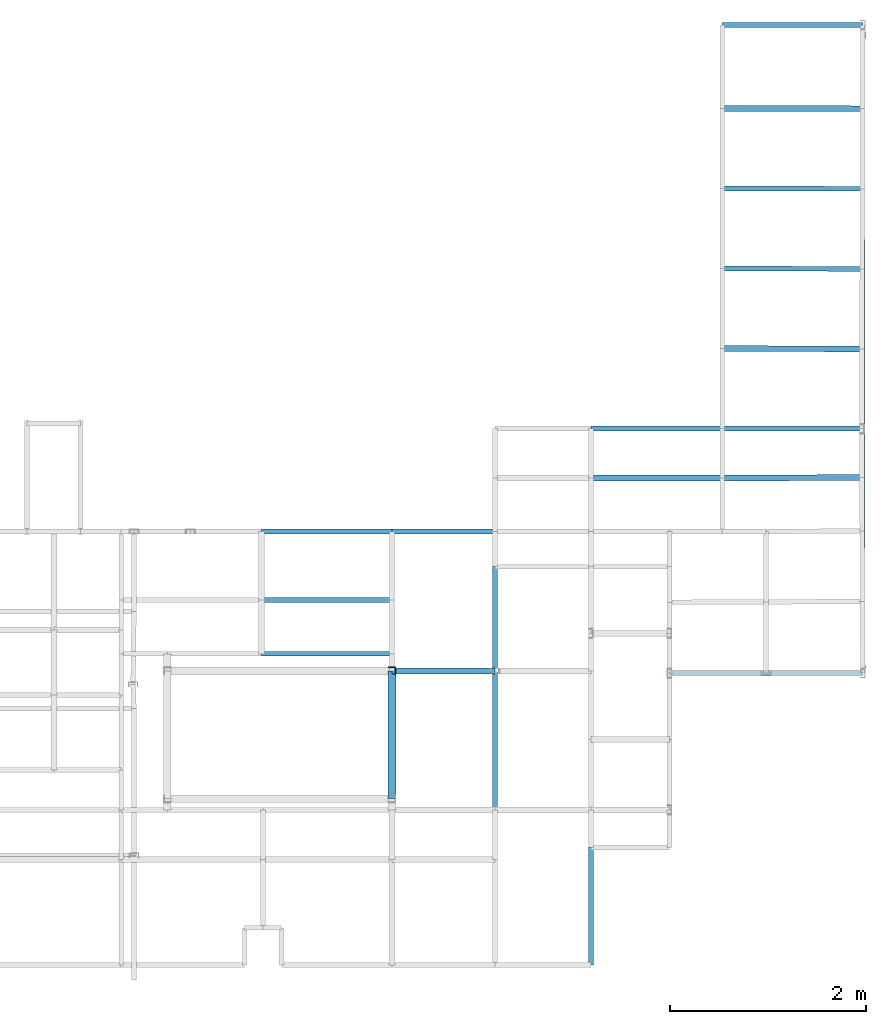
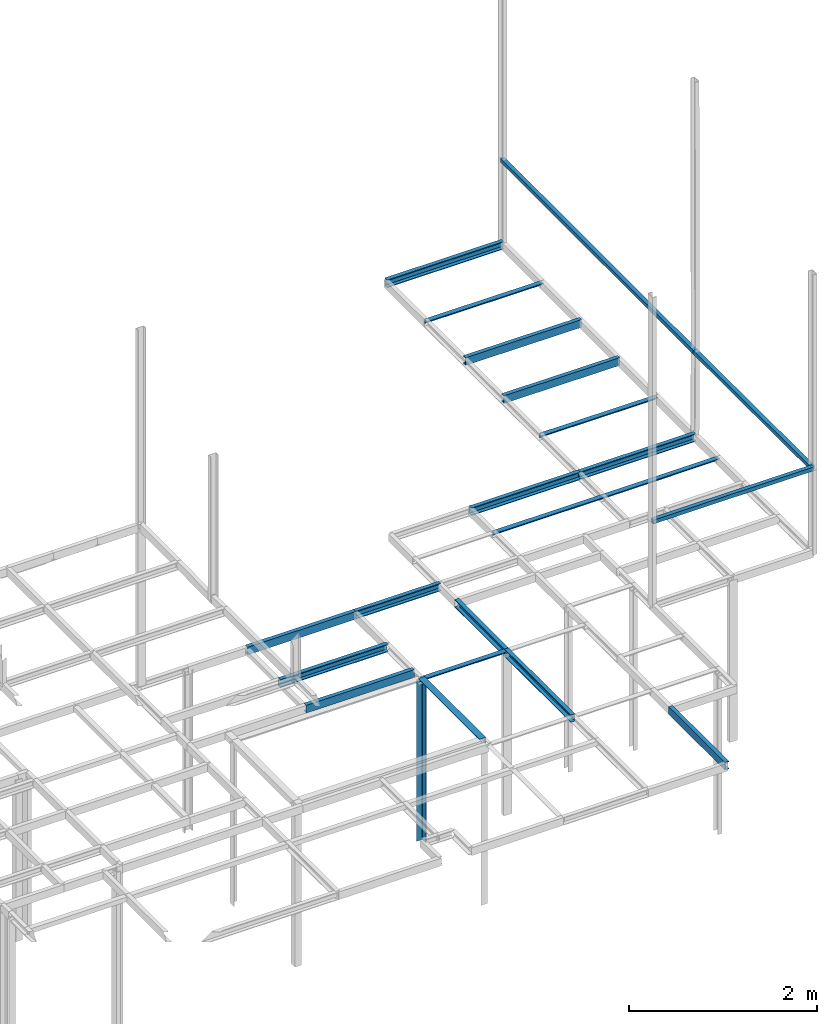
# Not in any storey, part 4 of 7: 21 beams, 1 member, 3 openings.
"""IFC2X3 model written with IfcOpenShell, lengths in centimetres."""

from ifc_helpers import new_model, si_unit, frame, frame_2d, origin_with_axes, origin_2d_with_axis, place, context, project, polyline, rectangle, l_section, u_section, outline, extrude, material, element, save


model = new_model("IFC2X3")

# Units and contexts
model_context = context("Model", 3, precision=1e-05, world=origin_with_axes())
plan_context = context("Plan", 3, precision=1e-05, world=origin_with_axes())
ifc_project = project(units=[si_unit("LENGTHUNIT", "METRE", prefix="CENTI"), si_unit("AREAUNIT", "SQUARE_METRE", prefix="CENTI"), si_unit("VOLUMEUNIT", "CUBIC_METRE", prefix="CENTI"), si_unit("PLANEANGLEUNIT", "RADIAN"), si_unit("SOLIDANGLEUNIT", "STERADIAN"), si_unit("MASSUNIT", "GRAM"), si_unit("TIMEUNIT", "SECOND"), si_unit("THERMODYNAMICTEMPERATUREUNIT", "DEGREE_CELSIUS"), si_unit("LUMINOUSINTENSITYUNIT", "LUMEN")], contexts=[model_context, plan_context])

# Member
ifc_material = material()
member_placement = place(None, frame((8.199999809265, 132.699996948242, 0.0), z_axis=(0.0, 0.0, 1.0), x_axis=(-1.0, 0.0, 0.0)))
element("IfcMember", 1, at=member_placement, material=ifc_material, context=model_context, shape_type="SweptSolid", body=[
    extrude(l_section(Depth=8.0, Width=8.0, Thickness=0.8, FilletRadius=1.0, EdgeRadius=0.0, LegSlope=0.0, CentreOfGravityInX=0.0, CentreOfGravityInY=0.0, at=origin_2d_with_axis()), origin_with_axes(), (0.0, 0.0, 1.0), 210.0),
])

# Beams
beam_1_placement = place(None, frame((488.5, 791.700012207031, 210.0), z_axis=(-1.0, 0.0, 0.0), x_axis=(0.0, -1.0, 0.0)))
element("IfcBeam", 2, at=beam_1_placement, material=ifc_material, Name="UPN - de ala UPN 100", context=model_context, shape_type="SweptSolid", body=[
    extrude(u_section(Depth=10.0, FlangeWidth=5.0, WebThickness=0.6, FlangeThickness=0.85, FilletRadius=0.0, EdgeRadius=0.0, FlangeSlope=0.0, CentreOfGravityInX=0.0, at=origin_2d_with_axis()), origin_with_axes(), (0.0, 0.0, 1.0), 143.399993896484),
])
beam_2_placement = place(None, frame((488.300018310547, 706.200012207031, 210.0), z_axis=(-0.999997805732, 0.002094882047, 0.0), x_axis=(0.0, 0.0, 1.0)))
element("IfcBeam", 3, at=beam_2_placement, material=ifc_material, context=model_context, shape_type="SweptSolid", body=[
    extrude(outline(polyline([(3.0, -3.000006586926), (3.0, 3.000006586926), (-3.0, 3.000006586926), (-3.0, 2.500005510415), (2.5, 2.500005510415), (2.5, -3.000006586926), (3.0, -3.000006586926)])), origin_with_axes(), (0.0, 0.0, 1.0), 143.200326426897),
])
beam_3_placement = place(None, frame((488.100006103516, 624.5, 210.0), z_axis=(-0.999996087374, 0.00279736258, 0.0), x_axis=(0.002797362627, 0.999996066093, 0.0)))
element("IfcBeam", 4, at=beam_3_placement, material=ifc_material, Name="UPN - de ala UPN 100", context=model_context, shape_type="SweptSolid", body=[
    extrude(u_section(Depth=10.0, FlangeWidth=5.0, WebThickness=0.6, FlangeThickness=0.85, FilletRadius=0.0, EdgeRadius=0.0, FlangeSlope=0.0, CentreOfGravityInX=0.0, at=frame_2d((-1.5323e-08, 0.0), x_axis=(1.0, 0.0))), origin_with_axes(), (0.0, 0.0, 1.0), 143.000559507758),
])
beam_4_placement = place(None, frame((487.899993896484, 542.799987792969, 210.0), z_axis=(-0.999996076406, 0.002801280663, 0.0), x_axis=(0.002801280702, 0.999996066093, 0.0)))
element("IfcBeam", 5, at=beam_4_placement, material=ifc_material, Name="UPN - de ala UPN 100", context=model_context, shape_type="SweptSolid", body=[
    extrude(u_section(Depth=10.0, FlangeWidth=5.0, WebThickness=0.6, FlangeThickness=0.85, FilletRadius=0.0, EdgeRadius=0.0, FlangeSlope=0.0, CentreOfGravityInX=0.0, at=frame_2d((-9.58e-09, 0.0), x_axis=(1.0, 0.0))), origin_with_axes(), (0.0, 0.0, 1.0), 142.800548084396),
])
beam_5_placement = place(None, frame((487.700012207031, 461.200012207031, 210.0), z_axis=(-0.999997787228, 0.002103696468, 0.0), x_axis=(0.0, 0.0, 1.0)))
element("IfcBeam", 6, at=beam_5_placement, material=ifc_material, context=model_context, shape_type="SweptSolid", body=[
    extrude(outline(polyline([(3.0, -3.000006651027), (3.0, 3.000006651027), (-3.0, 3.000006651027), (-3.0, 2.500005510422), (2.5, 2.500005510422), (2.5, -3.000006651027), (3.0, -3.000006651027)])), origin_with_axes(), (0.0, 0.0, 1.0), 142.600321645495),
])
beam_6_placement = place(None, frame((345.100006103516, 379.800018310547, 210.0), z_axis=(-1.0, 0.0, 0.0), x_axis=(0.0, -1.0, 0.0)))
element("IfcBeam", 7, at=beam_6_placement, material=ifc_material, Name="UPN - de ala UPN 100", context=model_context, shape_type="SweptSolid", body=[
    extrude(u_section(Depth=10.0, FlangeWidth=5.0, WebThickness=0.6, FlangeThickness=0.85, FilletRadius=0.0, EdgeRadius=0.0, FlangeSlope=0.0, CentreOfGravityInX=0.0, at=origin_2d_with_axis()), origin_with_axes(), (0.0, 0.0, 1.0), 134.0),
])
beam_7_placement = place(None, frame((487.5, 379.800018310547, 210.0), z_axis=(-1.0, 0.0, 0.0), x_axis=(0.0, -1.0, 0.0)))
element("IfcBeam", 8, at=beam_7_placement, material=ifc_material, Name="UPN - de ala UPN 100", context=model_context, shape_type="SweptSolid", body=[
    extrude(u_section(Depth=10.0, FlangeWidth=5.0, WebThickness=0.6, FlangeThickness=0.85, FilletRadius=0.0, EdgeRadius=0.0, FlangeSlope=0.0, CentreOfGravityInX=0.0, at=origin_2d_with_axis()), origin_with_axes(), (0.0, 0.0, 1.0), 142.399993896484),
])
beam_8_placement = place(None, frame((345.100006103516, 329.399993896484, 210.0), z_axis=(0.9999911481, 0.004207579009, 0.0), x_axis=(-0.004207578953, 0.999991118908, 0.0)))
element("IfcBeam", 9, at=beam_8_placement, material=ifc_material, context=model_context, shape_type="SweptSolid", body=[
    extrude(outline(polyline([(2.999995989513, -2.999999912423), (2.999995989513, 2.999999912423), (-2.999996008759, 2.999999912423), (-2.999996008759, 2.499999927019), (2.499991570106, 2.499999927019), (2.499991570106, -2.999999912423), (2.999995989513, -2.999999912423)])), origin_with_axes(), (0.0, 0.0, 1.0), 142.601268395646),
])
beam_9_placement = place(None, frame((345.100006103516, 329.399993896484, 210.0), z_axis=(-1.0, 0.0, 0.0), x_axis=(0.0, 0.0, 1.0)))
element("IfcBeam", 10, at=beam_9_placement, material=ifc_material, context=model_context, shape_type="SweptSolid", body=[
    extrude(outline(polyline([(3.0, -3.0), (3.0, 3.0), (-3.0, 3.0), (-3.0, 2.5), (2.5, 2.5), (2.5, -3.0), (3.0, -3.0)])), origin_with_axes(), (0.0, 0.0, 1.0), 134.0),
])
beam_10_placement = place(None, frame((8.200004577637, 275.0, 210.0), z_axis=(-1.0, 0.0, 0.0), x_axis=(0.0, 1.0, 0.0)))
element("IfcBeam", 11, at=beam_10_placement, material=ifc_material, Name="UPN - de ala UPN 100", context=model_context, shape_type="SweptSolid", body=[
    extrude(u_section(Depth=10.0, FlangeWidth=5.0, WebThickness=0.6, FlangeThickness=0.85, FilletRadius=0.0, EdgeRadius=0.0, FlangeSlope=0.0, CentreOfGravityInX=0.0, at=origin_2d_with_axis()), origin_with_axes(), (0.0, 0.0, 1.0), 133.100006103516),
])
beam_11_placement = place(None, frame((113.100001335144, 275.0, 210.0), z_axis=(-1.0, 0.0, 0.0), x_axis=(0.0, -1.0, 0.0)))
element("IfcBeam", 12, at=beam_11_placement, material=ifc_material, Name="UPN - de ala UPN 100", context=model_context, shape_type="SweptSolid", body=[
    extrude(u_section(Depth=10.0, FlangeWidth=5.0, WebThickness=0.6, FlangeThickness=0.85, FilletRadius=0.0, EdgeRadius=0.0, FlangeSlope=0.0, CentreOfGravityInX=0.0, at=origin_2d_with_axis()), origin_with_axes(), (0.0, 0.0, 1.0), 104.900001525879),
])
beam_12_placement = place(None, frame((113.099998474121, 132.699996948242, 210.0), z_axis=(0.0, 1.0, 0.0), x_axis=(-1.0, 0.0, 0.0)))
element("IfcBeam", 13, at=beam_12_placement, material=ifc_material, Name="UPN - de ala UPN 100", context=model_context, shape_type="SweptSolid", body=[
    extrude(u_section(Depth=10.0, FlangeWidth=5.0, WebThickness=0.6, FlangeThickness=0.85, FilletRadius=0.0, EdgeRadius=0.0, FlangeSlope=0.0, CentreOfGravityInX=0.0, at=origin_2d_with_axis()), origin_with_axes(), (0.0, 0.0, 1.0), 106.300003051758),
])
for number, where, z_axis, x_axis, name in (
    (14, (8.200004577637, 205.199996948242, 210.0), (-1.0, 0.0, 0.0), (0.0, -1.0, 0.0), "UPN - de ala UPN 100"),
    (15, (8.200004577637, 150.199996948242, 210.0), (-1.0, 0.0, 0.0), (0.0, 1.0, 0.0), "UPN - de ala UPN 100"),
):
    element("IfcBeam", number, at=place(None, frame(where, z_axis=z_axis, x_axis=x_axis)), material=ifc_material, Name=name, context=model_context, shape_type="SweptSolid", body=[
        extrude(u_section(Depth=10.0, FlangeWidth=5.0, WebThickness=0.6, FlangeThickness=0.85, FilletRadius=0.0, EdgeRadius=0.0, FlangeSlope=0.0, CentreOfGravityInX=0.0, at=origin_2d_with_axis()), origin_with_axes(), (0.0, 0.0, 1.0), 133.100006103516),
    ])
beam_13_placement = place(None, frame((113.100001335144, 132.699996948242, 210.0), z_axis=(-1.0, 0.0, 0.0), x_axis=(0.0, 0.0, 1.0)))
element("IfcBeam", 16, at=beam_13_placement, material=ifc_material, context=model_context, shape_type="SweptSolid", body=[
    extrude(outline(polyline([(3.0, -3.0), (3.0, 3.0), (-3.0, 3.0), (-3.0, 2.5), (2.5, 2.5), (2.5, -3.0), (3.0, -3.0)])), origin_with_axes(), (0.0, 0.0, 1.0), 104.900001525879),
])
beam_14_placement = place(None, frame((8.199999809265, 2.300003051758, 210.0), z_axis=(0.0, 1.0, 0.0), x_axis=(0.0, 0.0, 1.0)))
element("IfcBeam", 17, at=beam_14_placement, material=ifc_material, context=model_context, shape_type="SweptSolid", body=[
    extrude(outline(polyline([(4.0, -4.0), (4.0, 4.0), (-4.0, 4.0), (-4.0, 3.199999809265), (3.199996948242, 3.199999809265), (3.199996948242, -4.0), (4.0, -4.0)])), origin_with_axes(), (0.0, 0.0, 1.0), 130.399993896484),
])
beam_15_placement = place(None, frame((113.099998474121, -9.0, 210.0), z_axis=(0.0, 1.0, 0.0), x_axis=(-1.0, 0.0, 0.0)))
element("IfcBeam", 18, at=beam_15_placement, material=ifc_material, Name="UPN - de ala UPN 100", context=model_context, shape_type="SweptSolid", body=[
    extrude(u_section(Depth=10.0, FlangeWidth=5.0, WebThickness=0.6, FlangeThickness=0.85, FilletRadius=0.0, EdgeRadius=0.0, FlangeSlope=0.0, CentreOfGravityInX=0.0, at=origin_2d_with_axis()), origin_with_axes(), (0.0, 0.0, 1.0), 141.699996948242),
])
beam_16_placement = place(None, frame((211.100006103516, -167.5, 210.0), z_axis=(0.0, 1.0, 0.0), x_axis=(1.0, 0.0, 0.0)))
element("IfcBeam", 19, at=beam_16_placement, material=ifc_material, Name="UPN - de ala UPN 100", context=model_context, shape_type="SweptSolid", body=[
    extrude(u_section(Depth=10.0, FlangeWidth=5.0, WebThickness=0.6, FlangeThickness=0.85, FilletRadius=0.0, EdgeRadius=0.0, FlangeSlope=0.0, CentreOfGravityInX=0.0, at=origin_2d_with_axis()), origin_with_axes(), (0.0, 0.0, 1.0), 120.099998474121),
])

# Beam, opening
placement_1 = place(None, frame((488.0, 379.800018310547, 320.0), z_axis=(0.001213885989, 0.99999926324, 0.0), x_axis=(0.999999284744, -0.00121388596, 0.0)))
beam_17 = element("IfcBeam", 20, at=placement_1, material=ifc_material, Name="Viga 50x5", context=model_context, shape_type="SweptSolid", body=[
    extrude(rectangle(XDim=5.000003832693, YDim=5.00000010752, at=frame_2d((2.2787e-08, 0.0), x_axis=(1.0, 0.0))), origin_with_axes(), (0.0, 0.0, 1.0), 411.900297368094),
])
element("IfcOpeningElement", 21, at=placement_1, cuts=beam_17, context=model_context, shape_type="SweptSolid", body=[
    extrude(outline(polyline([(2.000001555865, -2.000000043008), (-2.00000151029, -2.000000043008), (-2.00000151029, 2.000000043008), (2.000001555865, 2.000000043008), (2.000001555865, -2.000000043008)])), origin_with_axes(), (0.0, 0.0, 1.0), 411.900297368094),
])

placement_2 = place(None, frame((488.5, 130.5, 320.0), z_axis=(-0.002005611543, 0.999997988759, 0.0), x_axis=(0.999997973442, 0.002005611546, 0.0)))
beam_18 = element("IfcBeam", 22, at=placement_2, material=ifc_material, Name="Viga 50x5", context=model_context, shape_type="SweptSolid", body=[
    extrude(rectangle(XDim=5.000009942912, YDim=4.999999923415, at=frame_2d((8.505e-09, 0.0), x_axis=(1.0, 0.0))), origin_with_axes(), (0.0, 0.0, 1.0), 249.300519713937),
])
element("IfcOpeningElement", 23, at=placement_2, cuts=beam_18, context=model_context, shape_type="SweptSolid", body=[
    extrude(outline(polyline([(2.000003973428, -1.999999969366), (-2.000003956419, -1.999999969366), (-2.000003956419, 1.999999969366), (2.000003973428, 1.999999969366), (2.000003973428, -1.999999969366)])), origin_with_axes(), (0.0, 0.0, 1.0), 249.300519713937),
])

placement_3 = place(None, frame((291.100006103516, 130.400009155273, 320.0), z_axis=(0.999999871709, 0.000506539184, 0.0), x_axis=(0.000506539189, -0.999999880791, 0.0)))
beam_19 = element("IfcBeam", 24, at=placement_3, material=ifc_material, Name="Viga 50x5", context=model_context, shape_type="SweptSolid", body=[
    extrude(rectangle(XDim=5.000000671538, YDim=5.000000045408, at=frame_2d((-3.1e-11, 0.0), x_axis=(1.0, 0.0))), origin_with_axes(), (0.0, 0.0, 1.0), 197.400019221126),
])
element("IfcOpeningElement", 25, at=placement_3, cuts=beam_19, context=model_context, shape_type="SweptSolid", body=[
    extrude(outline(polyline([(2.000000271676, -2.000000018163), (-2.000000271738, -2.000000018163), (-2.000000271738, 2.000000018163), (2.000000271676, 2.000000018163), (2.000000271676, -2.000000018163)])), origin_with_axes(), (0.0, 0.0, 1.0), 197.400019221126),
])

save(model, "model.ifc")
